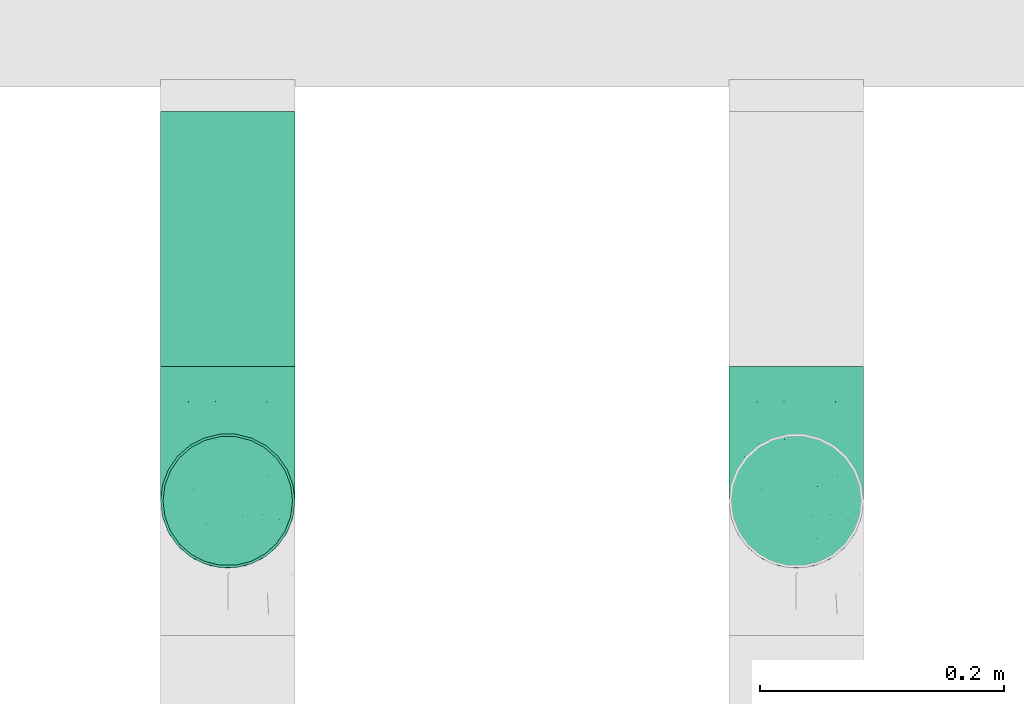
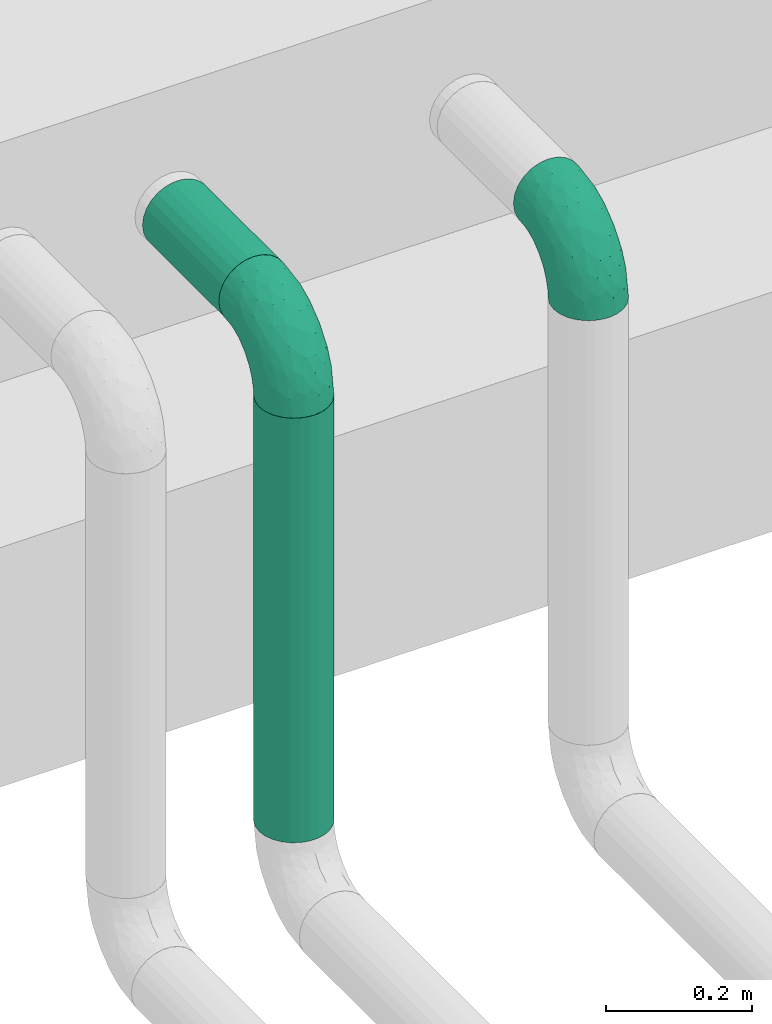
# One storey, part 59 of 91: 2 flow fittings, 2 flow segments.
"""IFC2X3 building model written with IfcOpenShell, lengths in millimetres."""

from ifc_helpers import new_model, entity, si_unit, converted_unit, derived_unit, direction, frame, origin_with_axes, origin_2d_with_axis, place, context, subcontext, project, spatial, hollow_circle, extrude, open_shell, surface_model, source, transform, mapped, material, layer, layer_set, layer_usage, type_object, element, save


model = new_model("IFC2X3")

# Units and contexts
model_context = context("Model", 3, precision=1e-05, world=origin_with_axes(), true_north=direction((0.0, 1.0)))
body_context = subcontext(model_context, "Body", "Model", "MODEL_VIEW")
ifc_project = project(units=[si_unit("AREAUNIT", "SQUARE_METRE"), si_unit("VOLUMEUNIT", "CUBIC_METRE", prefix="DECI"), si_unit("TIMEUNIT", "SECOND"), si_unit("THERMODYNAMICTEMPERATUREUNIT", "DEGREE_CELSIUS"), si_unit("PRESSUREUNIT", "PASCAL"), si_unit("MASSUNIT", "GRAM", prefix="KILO"), si_unit("LENGTHUNIT", "METRE", prefix="MILLI"), si_unit("POWERUNIT", "WATT"), si_unit("ELECTRICCURRENTUNIT", "AMPERE"), si_unit("ELECTRICVOLTAGEUNIT", "VOLT"), derived_unit("VOLUMETRICFLOWRATEUNIT", [(si_unit("VOLUMEUNIT", "CUBIC_METRE", prefix="DECI"), 1), (si_unit("TIMEUNIT", "SECOND"), -1)]), derived_unit("LINEARVELOCITYUNIT", [(si_unit("LENGTHUNIT", "METRE"), 1), (si_unit("TIMEUNIT", "SECOND"), -1)]), derived_unit("MASSDENSITYUNIT", [(si_unit("MASSUNIT", "GRAM", prefix="KILO"), 1), (si_unit("VOLUMEUNIT", "CUBIC_METRE"), -1)]), converted_unit("PLANEANGLEUNIT", "DEGREE", entity("IfcRatioMeasure", 0.01745), si_unit("PLANEANGLEUNIT", "RADIAN"), dimensions=[0, 0, 0, 0, 0, 0, 0])], contexts=[model_context])

# Site, building, storey
site_placement = place(None, origin_with_axes())
site = spatial("IfcSite", under=ifc_project, at=site_placement, CompositionType="ELEMENT")
building_placement = place(site_placement, origin_with_axes())
building = spatial("IfcBuilding", under=site, at=building_placement, Name="mc-building", CompositionType="ELEMENT")
storey_placement = place(building_placement, frame((0.0, 0.0, 8700.0), z_axis=(0.0, 0.0, 1.0), x_axis=(1.0, 0.0, 0.0)))
storey = spatial("IfcBuildingStorey", under=building, at=storey_placement, CompositionType="ELEMENT", Elevation=8700.0)

# Flow segments
ifc_material = material(Name="FZ1")
ifc_layer = layer(ifc_material, 0.0)
ifc_layer_set = layer_set([ifc_layer], Name="FZ1")
ifc_layer_usage = layer_usage(ifc_layer_set, "AXIS1", "POSITIVE", 0.0)
duct_segment_type = type_object("IfcDuctSegmentType", PredefinedType="RIGIDSEGMENT")
shared_shape_1 = source(origin_with_axes(), body_context, "Body", "SweptSolid", [
    extrude(hollow_circle(Radius=55.0, WallThickness=2.0, at=origin_2d_with_axis()), frame((0.0, 0.0, 0.0), z_axis=(1.0, 0.0, 0.0), x_axis=(0.0, 1.0, 0.0)), (0.0, 0.0, 1.0), 709.0),
])
flow_segment_1_placement = place(storey_placement, frame((30053.28275, 2612.35324, 1234.0), z_axis=(0.0, 1.0, 0.0), x_axis=(0.0, 0.0, -1.0)))
element("IfcFlowSegment", 1, at=flow_segment_1_placement, inside=storey, type_object=duct_segment_type, material=ifc_layer_usage, context=body_context, shape_type="MappedRepresentation", body=[
    mapped(shared_shape_1, transform((0.0, 0.0, 0.0), scale=1.0)),
])
shared_shape_2 = source(origin_with_axes(), body_context, "Body", "SweptSolid", [
    extrude(hollow_circle(Radius=55.0, WallThickness=2.0, at=origin_2d_with_axis()), frame((0.0, 0.0, 0.0), z_axis=(1.0, 0.0, 0.0), x_axis=(0.0, 1.0, 0.0)), (0.0, 0.0, 1.0), 208.9),
])
flow_segment_2_placement = place(storey_placement, frame((30053.28275, 2931.20513, 1344.0), z_axis=(0.0, 0.0, 1.0), x_axis=(0.0, -1.0, 0.0)))
element("IfcFlowSegment", 2, at=flow_segment_2_placement, inside=storey, type_object=duct_segment_type, material=ifc_layer_usage, context=body_context, shape_type="MappedRepresentation", body=[
    mapped(shared_shape_2, transform((0.0, 0.0, 0.0), scale=1.0)),
])

# Flow fittings
duct_fitting_type = type_object("IfcDuctFittingType", Name="BU", PredefinedType="BEND")
shared_shape_3 = source(origin_with_axes(), body_context, "Body", "SurfaceModel", [
    surface_model("IfcShellBasedSurfaceModel", [(-110.0, 0.0, -55.0), (-110.0, -14.23505, -53.12592), (-110.0, 14.23505, -53.12592), (-110.0, 53.12592, 14.23505), (-110.0, 27.5, -47.63139), (-110.0, 38.89087, -38.89087), (-110.0, -55.0, 0.0), (-110.0, -53.12592, 14.23505), (-110.0, -38.89087, -38.89087), (-110.0, -27.5, -47.63139), (-110.0, -53.12592, -14.23505), (-110.0, -47.63139, -27.5), (-110.0, -14.23505, 53.12592), (-110.0, 14.23505, 53.12592), (-110.0, 27.5, 47.63139), (-110.0, -47.63139, 27.5), (-110.0, -38.89087, 38.89087), (-110.0, -27.5, 47.63139), (-110.0, 0.0, 55.0), (-110.0, 55.0, 0.0), (-110.0, 53.12592, -14.23505), (-110.0, 47.63139, -27.5), (-110.0, 47.63139, 27.5), (-110.0, 38.89087, 38.89087), (-14.23505, 110.0, -53.12592), (-55.0, 110.0, 0.0), (0.0, 110.0, -55.0), (-27.5, 110.0, -47.63139), (-38.89087, 110.0, -38.89087), (-47.63139, 110.0, -27.5), (38.89087, 110.0, -38.89087), (53.12592, 110.0, 14.23505), (27.5, 110.0, -47.63139), (14.23505, 110.0, -53.12592), (47.63139, 110.0, -27.5), (53.12592, 110.0, -14.23505), (55.0, 110.0, 0.0), (-53.12592, 110.0, -14.23505), (-53.12592, 110.0, 14.23505), (-47.63139, 110.0, 27.5), (-38.89087, 110.0, 38.89087), (-27.5, 110.0, 47.63139), (0.0, 110.0, 55.0), (-14.23505, 110.0, 53.12592), (38.89087, 110.0, 38.89087), (47.63139, 110.0, 27.5), (27.5, 110.0, 47.63139), (14.23505, 110.0, 53.12592), (-64.21732, 48.68956, 43.63444), (-76.6405, 38.18013, 45.55988), (-60.44912, 32.56953, 51.94617), (-76.00813, 5.38378, 55.0), (-90.15553, 11.94394, 54.09138), (-78.5998, 26.77405, 50.81338), (-70.18771, 18.55163, 54.03432), (-75.55424, 54.2118, 32.41257), (-93.27622, 45.77614, 33.48188), (-96.12334, 22.13664, 50.81337), (-21.00813, 45.34362, 55.0), (-18.36258, 70.48427, 54.04484), (-32.04182, 59.64019, 52.24446), (-63.88653, 74.77858, 17.99134), (-74.66383, 63.08407, 19.92123), (-63.60674, 66.07878, 29.97482), (-99.597, 52.72185, 18.52927), (-93.11138, 56.59448, 10.50359), (-98.21577, 57.34403, 0.0), (-53.42855, 92.60092, 21.04759), (-88.54852, 54.8376, 21.04759), (-11.86161, 90.23965, 54.10313), (-5.38378, 76.00813, 55.0), (-57.34403, 98.21577, 0.0), (-56.64619, 93.12774, 10.22088), (-45.34362, 21.00813, 55.0), (-44.60838, 44.60838, 52.13415), (-92.68484, 35.46673, 43.63443), (-22.25266, 95.40765, 50.81337), (-35.97783, 90.61597, 43.63443), (-43.70931, 69.58671, 44.47149), (-27.23711, 77.39884, 50.81337), (-57.2828, 79.3123, 24.9774), (-58.67786, 84.31125, 16.04456), (-82.93277, 60.36161, 12.91784), (-49.88337, 54.51816, 47.224), (-74.57753, 66.83759, 9.55742), (-45.35812, 94.97281, 33.48188), (-59.18663, 88.95241, 0.0), (-51.517, 78.6292, 33.48188), (-65.14788, 80.03077, 0.0), (-56.45322, 62.06476, 39.63545), (-88.95241, 59.18663, 0.0), (-71.10913, 71.10913, 0.0), (-80.03077, 65.14788, 0.0), (-94.9309, 45.36788, -33.48188), (-93.11358, 56.60141, -10.46614), (-99.64997, 52.79499, -18.30015), (-90.20425, 36.08686, -43.63443), (-79.99933, 46.56772, -37.92748), (-76.00813, 5.38378, -55.0), (-72.75364, 19.68651, -53.60527), (-45.34362, 21.00813, -55.0), (-21.91957, 65.12078, -53.85897), (-5.38378, 76.00813, -55.0), (-21.00813, 45.34362, -55.0), (-35.41876, 92.89265, -43.63443), (-91.10309, 11.02766, -54.21832), (-45.77614, 93.27622, -33.48188), (-90.50474, 23.21022, -50.81337), (-70.92854, 33.31794, -49.51754), (-78.52933, 63.35627, -11.73997), (-24.91508, 84.05606, -50.81337), (-88.78941, 54.74452, -21.04759), (-69.59921, 57.34866, -33.48187), (-73.36422, 62.46673, -22.94182), (-63.49062, 67.59111, -28.46929), (-56.59448, 93.11138, -10.50359), (-54.8376, 88.54852, -21.04759), (-54.10679, 75.85581, -32.31867), (-57.75956, 31.09612, -52.80882), (-52.72185, 99.597, -18.52927), (-12.62913, 89.46304, -53.99097), (-34.46825, 66.46123, -50.04329), (-43.9837, 43.9837, -52.42279), (-65.78527, 72.58348, -17.68796), (-70.34468, 43.65295, -44.21951), (-57.47001, 51.99467, -44.91465), (-60.72547, 82.29174, -12.88567), (-42.34915, 74.24548, -43.63444), (-57.25194, 63.5016, -38.08211), (-80.95344, 53.56991, -29.32027), (-52.32891, 4.55257, -54.0482), (32.52942, 47.13398, -30.48571), (14.88266, 20.92917, -33.7947), (14.95561, 36.05775, -42.26543), (30.24048, 70.09027, -41.7461), (19.3559, 65.35825, -48.00507), (-70.35075, -46.44478, -19.5952), (-47.13398, -32.52942, -30.48571), (-28.49299, -30.5778, -16.4009), (-4.55257, 52.32891, -54.0482), (-22.4954, 22.4954, -53.25347), (-75.47368, -11.22546, -52.60718), (-81.32209, -51.5606, -9.98467), (-80.81763, -41.84862, -32.14655), (-70.09027, -30.24048, -41.7461), (-36.05774, -14.95561, -42.26543), (-9.15831, -10.852, -27.8997), (-65.35825, -19.3559, -48.00507), (11.22546, 75.47368, -52.60718), (3.94376, 43.9333, -50.53315), (-13.39742, 13.39743, -48.13058), (-43.9333, -3.94376, -50.53315), (49.37776, 67.29486, 0.0), (41.8609, 47.82256, -9.92641), (50.20582, 74.51695, -9.9731), (18.93131, 11.7156, -17.56239), (-27.5, -32.89419, 0.0), (-1.23348, -12.25375, -12.18106), (41.84862, 80.81763, -32.14655), (35.70604, 41.31408, -20.38235), (46.44478, 70.35075, -19.5952), (32.89419, 27.5, 0.0), (6.67262, -6.67262, 0.0), (-67.29486, -49.37776, 0.0), (-50.36265, -42.95545, -9.51562), (-5.47251, 5.47251, -39.92906), (-70.35075, -46.44478, 19.5952), (-74.51695, -50.20582, 9.9731), (-41.31407, -35.70604, 20.38235), (-47.13398, -32.52942, 30.48571), (-80.81763, -41.84862, 32.14655), (-4.55257, 52.32891, 54.0482), (11.22546, 75.47368, 52.60718), (-43.9333, -3.94376, 50.53315), (-65.35825, -19.3559, 48.00507), (-36.05774, -14.95561, 42.26543), (-70.09027, -30.24048, 41.7461), (-11.7156, -18.93131, 17.56239), (30.5778, 28.49299, 16.4009), (12.25375, 1.23348, 12.18106), (51.5606, 81.32209, 9.98467), (42.95545, 50.36265, 9.51562), (-75.47368, -11.22546, 52.60718), (-52.32891, 4.55257, 54.0482), (3.94376, 43.9333, 50.53315), (-22.4954, 22.4954, 53.25347), (-13.39742, 13.39743, 48.13058), (10.852, 9.15831, 27.8997), (-20.92916, -14.88266, 33.79469), (-47.82256, -41.8609, 9.92641), (32.52942, 47.13398, 30.48571), (46.44478, 70.35075, 19.5952), (41.84862, 80.81763, 32.14655), (30.24048, 70.09027, 41.7461), (19.3559, 65.35825, 48.00507), (14.95561, 36.05775, 42.26543), (-5.47251, 5.47251, 39.92906)], [open_shell([[[0, 1, 2]], [[2, 3, 4]], [[4, 3, 5]], [[2, 6, 7]], [[8, 6, 9]], [[1, 9, 6]], [[10, 6, 11]], [[8, 11, 6]], [[6, 2, 1]], [[12, 13, 14]], [[15, 2, 7]], [[16, 17, 2]], [[2, 17, 12]], [[12, 18, 13]], [[19, 20, 3]], [[5, 3, 21]], [[20, 21, 3]], [[22, 3, 2]], [[23, 22, 2]], [[12, 14, 2]], [[2, 14, 23]], [[15, 16, 2]], [[24, 25, 26]], [[27, 25, 24]], [[25, 28, 29]], [[28, 25, 27]], [[30, 26, 31]], [[26, 30, 32]], [[32, 33, 26]], [[34, 31, 35]], [[31, 34, 30]], [[35, 31, 36]], [[29, 37, 25]], [[38, 39, 26]], [[39, 40, 26]], [[41, 42, 40]], [[42, 26, 40]], [[42, 41, 43]], [[26, 44, 45]], [[31, 26, 45]], [[26, 46, 44]], [[47, 46, 26]], [[42, 47, 26]], [[25, 38, 26]], [[48, 49, 50]], [[18, 51, 52]], [[53, 54, 50]], [[55, 56, 49]], [[56, 22, 23]], [[13, 57, 14]], [[58, 59, 60]], [[61, 62, 63]], [[3, 64, 65]], [[53, 52, 54]], [[3, 65, 66]], [[67, 39, 38]], [[56, 68, 64]], [[65, 64, 68]], [[69, 59, 70]], [[38, 71, 72]], [[73, 58, 74]], [[75, 49, 56]], [[76, 69, 43]], [[53, 57, 52]], [[77, 78, 79]], [[41, 76, 43]], [[43, 69, 42]], [[55, 68, 56]], [[23, 14, 75]], [[76, 77, 79]], [[80, 67, 81]], [[62, 82, 68]], [[60, 78, 83]], [[62, 84, 82]], [[85, 77, 40]], [[81, 67, 72]], [[86, 72, 71]], [[87, 85, 67]], [[61, 81, 88]], [[77, 41, 40]], [[78, 77, 87]], [[23, 75, 56]], [[83, 89, 48]], [[85, 40, 39]], [[62, 68, 55]], [[89, 87, 63]], [[83, 48, 50]], [[57, 75, 14]], [[49, 75, 53]], [[67, 85, 39]], [[87, 77, 85]], [[63, 62, 55]], [[89, 55, 48]], [[80, 63, 87]], [[66, 65, 90]], [[66, 19, 3]], [[84, 91, 92]], [[92, 90, 82]], [[65, 82, 90]], [[61, 84, 62]], [[92, 82, 84]], [[68, 82, 65]], [[3, 22, 64]], [[56, 64, 22]], [[38, 25, 71]], [[81, 72, 86]], [[38, 72, 67]], [[91, 61, 88]], [[80, 81, 61]], [[63, 80, 61]], [[67, 80, 87]], [[77, 76, 41]], [[79, 59, 69]], [[79, 69, 76]], [[42, 69, 70]], [[60, 59, 79]], [[58, 70, 59]], [[78, 60, 79]], [[58, 60, 74]], [[52, 57, 13]], [[75, 57, 53]], [[18, 52, 13]], [[52, 51, 54]], [[51, 73, 54]], [[50, 73, 74]], [[73, 50, 54]], [[50, 74, 83]], [[60, 83, 74]], [[89, 83, 78]], [[87, 89, 78]], [[55, 89, 63]], [[50, 49, 53]], [[55, 49, 48]], [[81, 86, 88]], [[91, 84, 61]], [[5, 21, 93]], [[90, 94, 66]], [[20, 94, 95]], [[96, 93, 97]], [[98, 99, 100]], [[96, 4, 5]], [[101, 102, 103]], [[28, 27, 104]], [[2, 105, 0]], [[104, 106, 28]], [[99, 105, 107]], [[108, 107, 96]], [[90, 109, 94]], [[107, 2, 4]], [[20, 66, 94]], [[27, 24, 110]], [[109, 111, 94]], [[112, 113, 114]], [[37, 115, 71]], [[116, 106, 117]], [[99, 118, 100]], [[116, 115, 119]], [[37, 119, 115]], [[24, 120, 110]], [[121, 110, 101]], [[119, 106, 116]], [[101, 110, 120]], [[122, 103, 100]], [[117, 123, 116]], [[124, 125, 108]], [[115, 116, 126]], [[106, 29, 28]], [[26, 102, 120]], [[127, 104, 110]], [[97, 124, 96]], [[125, 122, 118]], [[128, 127, 125]], [[96, 5, 93]], [[115, 126, 86]], [[117, 106, 127]], [[111, 113, 129]], [[95, 93, 21]], [[97, 129, 112]], [[110, 104, 27]], [[106, 104, 127]], [[96, 107, 4]], [[99, 107, 108]], [[99, 108, 118]], [[105, 99, 98]], [[112, 114, 128]], [[121, 125, 127]], [[20, 19, 66]], [[109, 90, 92]], [[94, 111, 95]], [[91, 123, 109]], [[129, 113, 112]], [[93, 95, 111]], [[21, 20, 95]], [[71, 115, 86]], [[71, 25, 37]], [[123, 91, 88]], [[126, 116, 123]], [[123, 88, 126]], [[86, 126, 88]], [[37, 29, 119]], [[106, 119, 29]], [[129, 93, 111]], [[124, 112, 125]], [[0, 105, 98]], [[107, 105, 2]], [[125, 118, 108]], [[100, 118, 122]], [[93, 129, 97]], [[113, 111, 109]], [[109, 123, 113]], [[114, 123, 117]], [[123, 114, 113]], [[128, 114, 117]], [[127, 128, 117]], [[112, 128, 125]], [[103, 122, 101]], [[110, 121, 127]], [[101, 122, 121]], [[125, 121, 122]], [[26, 120, 24]], [[101, 120, 102]], [[96, 124, 108]], [[92, 91, 109]], [[112, 124, 97]], [[100, 130, 98]], [[131, 132, 133]], [[32, 134, 135]], [[136, 137, 138]], [[139, 140, 103]], [[98, 141, 0]], [[142, 10, 136]], [[143, 144, 137]], [[6, 10, 142]], [[137, 145, 146]], [[144, 147, 145]], [[143, 136, 11]], [[11, 136, 10]], [[8, 143, 11]], [[148, 149, 139]], [[8, 9, 144]], [[9, 1, 147]], [[130, 141, 98]], [[103, 140, 100]], [[148, 135, 149]], [[150, 151, 140]], [[152, 153, 154]], [[130, 140, 151]], [[148, 26, 33]], [[147, 1, 141]], [[155, 146, 132]], [[156, 138, 157]], [[134, 30, 158]], [[150, 140, 149]], [[158, 30, 34]], [[30, 134, 32]], [[153, 159, 160]], [[131, 160, 159]], [[144, 145, 137]], [[36, 152, 154]], [[146, 138, 137]], [[155, 161, 162]], [[158, 160, 131]], [[133, 149, 135]], [[156, 163, 164]], [[163, 142, 164]], [[139, 103, 102]], [[153, 152, 161]], [[34, 35, 160]], [[162, 157, 155]], [[132, 165, 133]], [[157, 146, 155]], [[140, 130, 100]], [[141, 130, 151]], [[141, 151, 147]], [[141, 1, 0]], [[102, 26, 148]], [[140, 139, 149]], [[102, 148, 139]], [[135, 33, 32]], [[151, 150, 145]], [[9, 147, 144]], [[151, 145, 147]], [[145, 165, 146]], [[135, 148, 33]], [[133, 135, 134]], [[131, 133, 134]], [[133, 165, 150]], [[133, 150, 149]], [[145, 150, 165]], [[132, 131, 159]], [[146, 165, 132]], [[160, 158, 34]], [[134, 158, 131]], [[144, 143, 8]], [[136, 143, 137]], [[155, 153, 161]], [[154, 153, 160]], [[153, 155, 159]], [[132, 159, 155]], [[160, 35, 154]], [[36, 154, 35]], [[164, 136, 138]], [[6, 142, 163]], [[136, 164, 142]], [[156, 164, 138]], [[156, 157, 162]], [[146, 157, 138]], [[15, 7, 166]], [[6, 163, 167]], [[168, 169, 166]], [[166, 169, 170]], [[171, 172, 70]], [[173, 174, 175]], [[17, 176, 174]], [[177, 156, 162]], [[176, 16, 170]], [[170, 16, 15]], [[161, 178, 179]], [[152, 180, 181]], [[182, 173, 183]], [[18, 12, 182]], [[184, 185, 186]], [[183, 185, 73]], [[183, 73, 51]], [[177, 187, 188]], [[189, 168, 166]], [[187, 178, 190]], [[16, 176, 17]], [[161, 152, 181]], [[45, 191, 31]], [[45, 44, 192]], [[192, 191, 45]], [[180, 36, 31]], [[193, 194, 195]], [[46, 47, 194]], [[193, 195, 190]], [[193, 44, 46]], [[172, 42, 70]], [[185, 58, 73]], [[189, 163, 156]], [[163, 189, 167]], [[70, 58, 171]], [[184, 171, 185]], [[169, 188, 175]], [[180, 31, 191]], [[192, 193, 190]], [[191, 190, 178]], [[182, 174, 173]], [[194, 47, 172]], [[190, 195, 187]], [[186, 185, 173]], [[162, 179, 177]], [[188, 196, 175]], [[179, 187, 177]], [[185, 171, 58]], [[172, 171, 184]], [[172, 184, 194]], [[172, 47, 42]], [[51, 18, 182]], [[185, 183, 173]], [[51, 182, 183]], [[174, 12, 17]], [[184, 186, 195]], [[46, 194, 193]], [[184, 195, 194]], [[195, 196, 187]], [[174, 182, 12]], [[175, 174, 176]], [[169, 175, 176]], [[175, 196, 186]], [[175, 186, 173]], [[195, 186, 196]], [[188, 169, 168]], [[187, 196, 188]], [[166, 170, 15]], [[176, 170, 169]], [[193, 192, 44]], [[191, 192, 190]], [[177, 189, 156]], [[167, 189, 166]], [[189, 177, 168]], [[188, 168, 177]], [[166, 7, 167]], [[6, 167, 7]], [[181, 191, 178]], [[36, 180, 152]], [[191, 181, 180]], [[161, 181, 178]], [[161, 179, 162]], [[187, 179, 178]]])]),
])
for number, where, z_axis, x_axis, name in (
    (3, (30518.54047, 2612.35324, 1344.0), (-1.0, 0.0, 0.0), (0.0, 0.0, 1.0), "BU"),
    (4, (30053.28275, 2612.35324, 1344.0), (-1.0, 0.0, 0.0), (0.0, 0.0, 1.0), "BU"),
):
    element("IfcFlowFitting", number, at=place(storey_placement, frame(where, z_axis=z_axis, x_axis=x_axis)), inside=storey, type_object=duct_fitting_type, Name=name, context=body_context, shape_type="MappedRepresentation", body=[
        mapped(shared_shape_3, transform((0.0, 0.0, 0.0), scale=1.0)),
    ])

save(model, "model.ifc")
